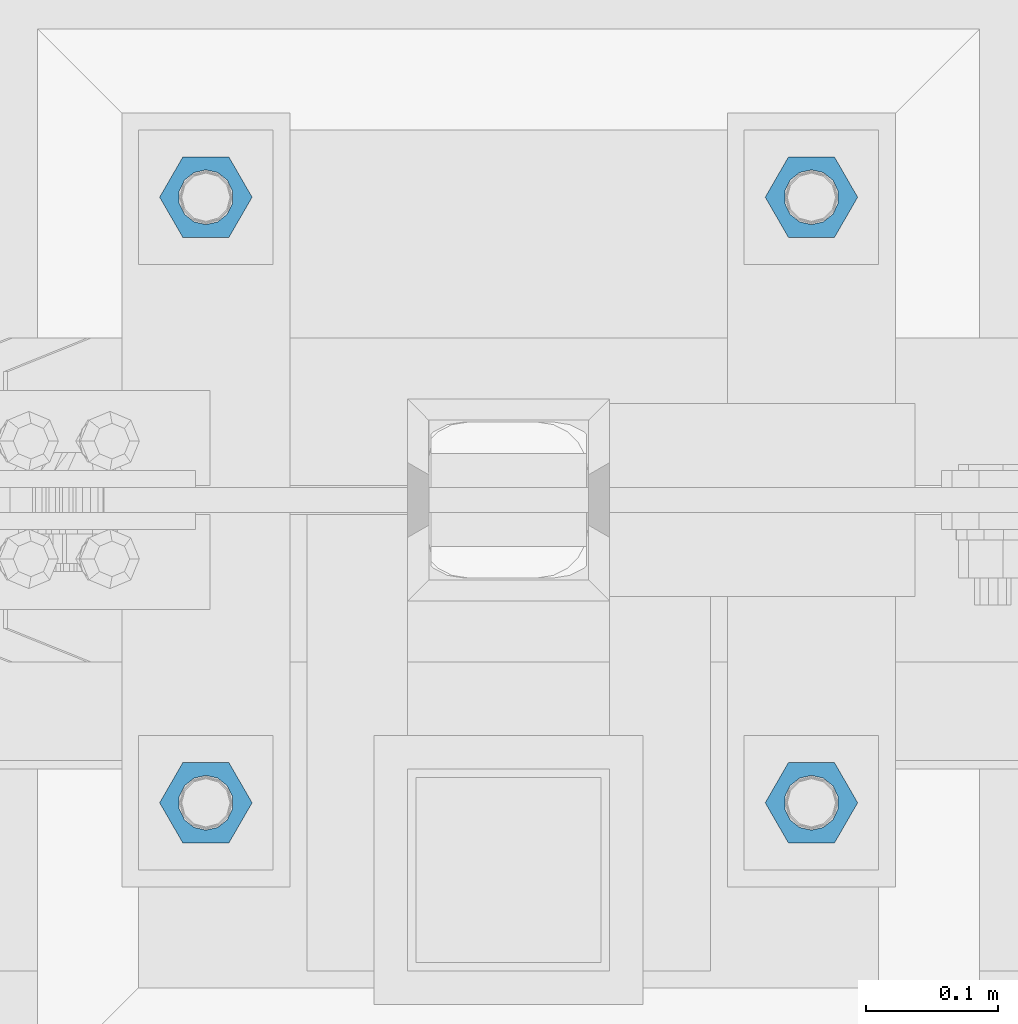
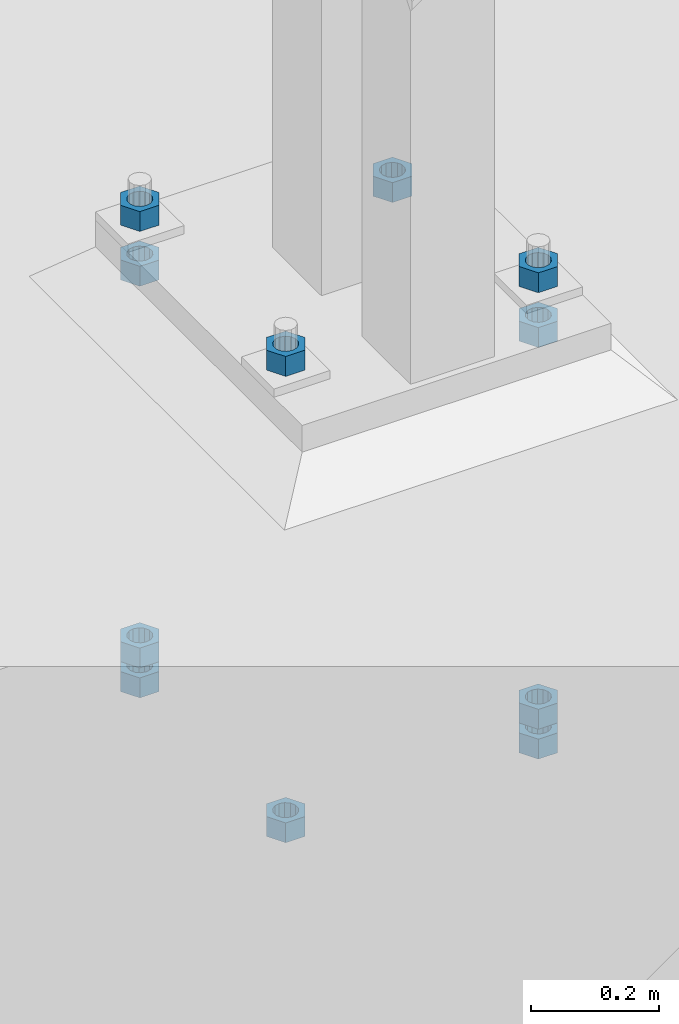
# One storey, part 960 of 1179: 11 beams, 1 element without a shape of its own.
"""IFC2X3 building model written with IfcOpenShell, lengths in millimetres."""

import ifcopenshell
import ifcopenshell.guid

model = None  # the IFC model being written
_history = None  # IfcOwnerHistory: only IFC2X3 demands one
_inside = {}  # id of a spatial element -> (the spatial element, [elements in it])
_under = {}  # id of a project, library or spatial element -> (it, [spatial elements below it])
_declared = {}  # id of a project -> (the project, [libraries it declares])
_typed = {}  # id of a type object -> (the type object, [elements of that type])
_made_of = {}  # id of a material, layer set ... -> (it, [elements and type objects made of it])


def new_model(schema):
    """Start an empty IFC model of exactly this schema.

    Asked for "IFC4X3", IfcOpenShell would pick the latest addendum, in which some entities
    have other attributes; the version numbers below select the first issue.
    IFC2X3 requires an IfcOwnerHistory on every rooted entity: one is made here for all.
    """
    global model, _history
    if schema == "IFC4X3":
        model = ifcopenshell.file(schema_version=(4, 3, 0, 0))
    else:
        model = ifcopenshell.file(schema=schema)
    _inside.clear()
    _under.clear()
    _declared.clear()
    _typed.clear()
    _made_of.clear()
    _history = None
    if model.schema == "IFC2X3":
        org = make("IfcOrganization", Name="unknown")
        user = make(
            "IfcPersonAndOrganization",
            ThePerson=make("IfcPerson", FamilyName="unknown"),
            TheOrganization=org,
        )
        app = make(
            "IfcApplication",
            ApplicationDeveloper=org,
            Version="unknown",
            ApplicationFullName="unknown",
            ApplicationIdentifier="unknown",
        )
        _history = make(
            "IfcOwnerHistory",
            OwningUser=user,
            OwningApplication=app,
            ChangeAction="ADDED",
            CreationDate=0,
        )
    return model


def make(cls, **values):
    """One entity of the class cls with the attributes given. An attribute that is None is left unset."""
    return model.create_entity(
        cls, **{name: value for name, value in values.items() if value is not None}
    )


def rooted(cls, **values):
    """An entity with a GlobalId (a new one), such as an element, a storey or a relation."""
    return make(cls, GlobalId=ifcopenshell.guid.new(), OwnerHistory=_history, **values)


def si_unit(unit_type, name, prefix=None):
    """IfcSIUnit, for example si_unit("LENGTHUNIT", "METRE", prefix="MILLI")."""
    return make("IfcSIUnit", UnitType=unit_type, Prefix=prefix, Name=name)


def assignment(units):
    """IfcUnitAssignment: the units of a project."""
    return None if units is None else make("IfcUnitAssignment", Units=units)


def point(xyz):
    """IfcCartesianPoint."""
    return None if xyz is None else make("IfcCartesianPoint", Coordinates=xyz)


def direction(xyz):
    """IfcDirection."""
    return None if xyz is None else make("IfcDirection", DirectionRatios=xyz)


def frame(location, z_axis=None, x_axis=None):
    """IfcAxis2Placement3D, a coordinate frame: its origin and axes. An axis left out is left unset."""
    return make(
        "IfcAxis2Placement3D",
        Location=point(location),
        Axis=direction(z_axis),
        RefDirection=direction(x_axis),
    )


def origin_with_axes():
    """The frame at (0, 0, 0) with the z axis (0, 0, 1) and the x axis (1, 0, 0) written out."""
    return frame((0.0, 0.0, 0.0), z_axis=(0.0, 0.0, 1.0), x_axis=(1.0, 0.0, 0.0))


def place(relative_to, where):
    """IfcLocalPlacement: puts the frame where relative to a parent placement (None: the world)."""
    return make(
        "IfcLocalPlacement", PlacementRelTo=relative_to, RelativePlacement=where
    )


def context(
    kind, dimensions, precision=None, world=None, true_north=None, identifier=None
):
    """IfcGeometricRepresentationContext, for example the 3D "Model" context."""
    return make(
        "IfcGeometricRepresentationContext",
        ContextIdentifier=identifier,
        ContextType=kind,
        CoordinateSpaceDimension=dimensions,
        Precision=precision,
        WorldCoordinateSystem=world,
        TrueNorth=true_north,
    )


def subcontext(parent, identifier, kind, view, scale=None):
    """IfcGeometricRepresentationSubContext, for example "Body" below "Model"."""
    return make(
        "IfcGeometricRepresentationSubContext",
        ContextIdentifier=identifier,
        ContextType=kind,
        ParentContext=parent,
        TargetScale=scale,
        TargetView=view,
    )


def project(units=None, contexts=None):
    """IfcProject with its units and contexts."""
    return rooted(
        "IfcProject",
        Name="project",
        RepresentationContexts=contexts,
        UnitsInContext=assignment(units),
    )


def spatial(cls, under=None, at=None, **own):
    """A site, building, storey or space (cls), placed at a placement, below another one or the project."""
    s = rooted(cls, ObjectPlacement=at, **own)
    if under is not None:
        _under.setdefault(under.id(), (under, []))[1].append(s)
    return s


def faces_of(points, faces, orient=None, outer=None):
    """IfcFace entities. A face is a list of loops; a loop is a list of indices into points, from 0.

    orient and outer hold one flag for each loop. By default every Orientation is true, the
    first loop of a face is its IfcFaceOuterBound and the others are IfcFaceBound.
    """
    made = []
    for i, loops in enumerate(faces):
        bounds = []
        for j, loop in enumerate(loops):
            is_outer = j == 0 if outer is None else outer[i][j]
            bounds.append(
                make(
                    "IfcFaceOuterBound" if is_outer else "IfcFaceBound",
                    Bound=make("IfcPolyLoop", Polygon=[points[k] for k in loop]),
                    Orientation=True if orient is None else orient[i][j],
                )
            )
        made.append(make("IfcFace", Bounds=bounds))
    return made


def faceted_brep(points, faces, orient=None, outer=None, voids=None):
    """IfcFacetedBrep: a solid bounded by flat faces; with voids (closed shells), ...WithVoids."""
    shared = [point(p) for p in points]
    hull = make("IfcClosedShell", CfsFaces=faces_of(shared, faces, orient, outer))
    if voids is None:
        return make("IfcFacetedBrep", Outer=hull)
    return make(
        "IfcFacetedBrepWithVoids",
        Outer=hull,
        Voids=[
            make(cls, CfsFaces=faces_of(shared, fs, o, b)) for cls, fs, o, b in voids
        ],
    )


def shape(context_of_items, identifier, shape_type, items):
    """IfcShapeRepresentation: the items that make up one representation, for example the "Body"."""
    return make(
        "IfcShapeRepresentation",
        ContextOfItems=context_of_items,
        RepresentationIdentifier=identifier,
        RepresentationType=shape_type,
        Items=items,
    )


def material(Name=None, Category=None):
    """IfcMaterial."""
    return make("IfcMaterial", Name=Name, Category=Category)


def made_of(thing, what):
    """Note that an element or type object is made of a material, layer set ...; save() writes the relation."""
    if what is not None:
        _made_of.setdefault(what.id(), (what, []))[1].append(thing)
    return thing


def type_object(cls, material=None, **own):
    """A type object (cls), such as IfcWallType, which elements share."""
    return made_of(rooted(cls, **own), material)


def element(
    cls,
    number,
    at=None,
    inside=None,
    cuts=None,
    type_object=None,
    material=None,
    context=None,
    identifier="Body",
    shape_type=None,
    held_by="IfcProductDefinitionShape",
    body=None,
    shapes=None,
    **own,
):
    """One element of the class cls, such as IfcWall. Its Tag is "e" and its number.

    at: its placement. inside: the storey or other place that contains it. cuts: it is an
    opening in that element (IfcRelVoidsElement). A single representation is given by context,
    identifier, shape_type and body (its items); several are given by shapes. held_by: the class
    of the entity that holds the representations. save() writes the other relations.
    """
    e = rooted(cls, Tag="e%d" % number, ObjectPlacement=at, **own)
    if body is not None:
        shapes = [shape(context, identifier, shape_type, body)]
    if shapes is not None:
        e.Representation = make(held_by, Representations=shapes)
    if inside is not None:
        _inside.setdefault(inside.id(), (inside, []))[1].append(e)
    if cuts is not None:
        rooted(
            "IfcRelVoidsElement", RelatingBuildingElement=cuts, RelatedOpeningElement=e
        )
    if type_object is not None:
        _typed.setdefault(type_object.id(), (type_object, []))[1].append(e)
    return made_of(e, material)


def aggregate(whole, parts):
    """IfcRelAggregates: a whole, such as a stair, and the parts it consists of."""
    return rooted("IfcRelAggregates", RelatingObject=whole, RelatedObjects=parts)


def save(model, path):
    """Write the relations noted so far, then the file.

    IfcRelAggregates (storeys below a building ...), IfcRelContainedInSpatialStructure (elements
    in a storey), IfcRelDefinesByType, IfcRelAssociatesMaterial and IfcRelDeclares: one each for
    every whole, place, type object, material and project.
    """
    for whole, parts in _under.values():
        aggregate(whole, parts)
    for where, things in _inside.values():
        rooted(
            "IfcRelContainedInSpatialStructure",
            RelatedElements=things,
            RelatingStructure=where,
        )
    for kind, things in _typed.values():
        rooted("IfcRelDefinesByType", RelatedObjects=things, RelatingType=kind)
    for what, things in _made_of.values():
        rooted("IfcRelAssociatesMaterial", RelatedObjects=things, RelatingMaterial=what)
    for by, libraries in _declared.values():
        rooted("IfcRelDeclares", RelatingContext=by, RelatedDefinitions=libraries)
    model.write(path)


model = new_model("IFC2X3")

# Units and contexts
model_context = context("Model", 3, precision=1e-05, world=origin_with_axes())
body_context = subcontext(model_context, "Body", "Model", "MODEL_VIEW")
ifc_project = project(units=[si_unit("LENGTHUNIT", "METRE", prefix="MILLI"), si_unit("AREAUNIT", "SQUARE_METRE"), si_unit("VOLUMEUNIT", "CUBIC_METRE"), si_unit("MASSUNIT", "GRAM", prefix="KILO"), si_unit("TIMEUNIT", "SECOND"), si_unit("PLANEANGLEUNIT", "RADIAN"), si_unit("SOLIDANGLEUNIT", "STERADIAN"), si_unit("THERMODYNAMICTEMPERATUREUNIT", "DEGREE_CELSIUS"), si_unit("LUMINOUSINTENSITYUNIT", "LUMEN")], contexts=[model_context])

# Site, building, storey
site_placement = place(None, origin_with_axes())
site = spatial("IfcSite", under=ifc_project, at=site_placement, CompositionType="ELEMENT")
building_placement = place(site_placement, origin_with_axes())
building = spatial("IfcBuilding", under=site, at=building_placement, Name="Undefined", CompositionType="ELEMENT")
storey_placement = place(building_placement, origin_with_axes())
storey = spatial("IfcBuildingStorey", under=building, at=storey_placement, Name="Undefined", CompositionType="ELEMENT", Elevation=0.0)

# Assembly, beams
assembly_placement = place(storey_placement, origin_with_axes())
assembly = element("IfcElementAssembly", 1, at=assembly_placement, inside=storey, Name="TEMPLATE", AssemblyPlace="NOTDEFINED", PredefinedType="RIGID_FRAME")
ifc_material = material(Name="STEEL/A36")
beam_type = type_object("IfcBeamType", Name="1-1/2_HEAVY_HEX_NUT", PredefinedType="NOTDEFINED")
beam_1_placement = place(assembly_placement, frame((27990.799987793, 4419.59999389648, -279.399999999999), z_axis=(0.0, 1.0, 0.0), x_axis=(0.0, 0.0, -1.0)))
beam_1 = element("IfcBeam", 2, at=beam_1_placement, type_object=beam_type, material=ifc_material, Name="NUT", ObjectType="1-1/2_HEAVY_HEX_NUT", context=body_context, shape_type="Brep", body=[
    faceted_brep([(0.0, -34.9199981689453, 0.0), (0.0, -17.4599990844727, -30.25), (38.0999999999985, -17.4599990844727, -30.25), (38.0999999999985, -34.9199981689453, 0.0), (0.0, 17.4599990844727, -30.25), (38.0999999999985, 17.4599990844727, -30.25), (0.0, 34.9199981689453, 0.0), (38.0999999999985, 34.9199981689453, 0.0), (0.0, 17.4599990844727, 30.25), (38.0999999999985, 17.4599990844727, 30.25), (0.0, -17.4599990844727, 30.25), (38.0999999999985, -17.4599990844727, 30.25), (0.0, 0.0, 20.6399993896484), (0.0, 8.95536011056538, 18.5959968835978), (38.0999999999985, 8.95536011056538, 18.5959968835978), (38.0999999999985, 0.0, 20.6399993896484), (0.0, 16.1370013209489, 12.8688291298158), (38.0999999999985, 16.1370013209489, 12.8688291298158), (0.0, 20.1225115123852, 4.59283194104228), (38.0999999999985, 20.1225115123852, 4.59283194104228), (0.0, 20.1225115123852, -4.59283194104228), (38.0999999999985, 20.1225115123852, -4.59283194104228), (0.0, 16.1370013209489, -12.8688291298167), (38.0999999999985, 16.1370013209489, -12.8688291298167), (0.0, 8.95536011056538, -18.5959968835978), (38.0999999999985, 8.95536011056538, -18.5959968835978), (0.0, 0.0, -20.6399993896484), (38.0999999999985, 0.0, -20.6399993896484), (0.0, -8.95536011056538, -18.5959968835978), (38.0999999999985, -8.95536011056538, -18.5959968835978), (0.0, -16.1370013209489, -12.8688291298158), (38.0999999999985, -16.1370013209489, -12.8688291298158), (0.0, -20.1225115123852, -4.59283194104228), (38.0999999999985, -20.1225115123852, -4.59283194104228), (0.0, -20.1225115123852, 4.59283194104228), (38.0999999999985, -20.1225115123852, 4.59283194104228), (0.0, -16.1370013209489, 12.8688291298167), (38.0999999999985, -16.1370013209489, 12.8688291298167), (0.0, -8.95536011056538, 18.5959968835978), (38.0999999999985, -8.95536011056538, 18.5959968835978)], [[[0, 1, 2, 3]], [[1, 4, 5, 2]], [[4, 6, 7, 5]], [[6, 8, 9, 7]], [[8, 10, 11, 9]], [[10, 0, 3, 11]], [[12, 13, 14, 15]], [[13, 16, 17, 14]], [[16, 18, 19, 17]], [[18, 20, 21, 19]], [[20, 22, 23, 21]], [[22, 24, 25, 23]], [[24, 26, 27, 25]], [[26, 28, 29, 27]], [[28, 30, 31, 29]], [[30, 32, 33, 31]], [[32, 34, 35, 33]], [[34, 36, 37, 35]], [[36, 38, 39, 37]], [[38, 12, 15, 39]], [[5, 7, 9, 11, 3, 2], [17, 19, 21, 23, 25, 27, 29, 31, 33, 35, 37, 39, 15, 14]], [[10, 8, 6, 4, 1, 0], [38, 36, 34, 32, 30, 28, 26, 24, 22, 20, 18, 16, 13, 12]]]),
])
beam_2_placement = place(assembly_placement, frame((27533.599987793, 4876.79999389648, -279.399999999999), z_axis=(0.0, -1.0, 0.0), x_axis=(0.0, 0.0, -1.0)))
beam_2 = element("IfcBeam", 3, at=beam_2_placement, type_object=beam_type, material=ifc_material, Name="NUT", ObjectType="1-1/2_HEAVY_HEX_NUT", context=body_context, shape_type="Brep", body=[
    faceted_brep([(0.0, -34.9199981689453, 0.0), (0.0, -17.4599990844727, -30.25), (38.0999999999985, -17.4599990844727, -30.25), (38.0999999999985, -34.9199981689453, 0.0), (0.0, 17.4599990844727, -30.25), (38.0999999999985, 17.4599990844727, -30.25), (0.0, 34.9199981689453, 0.0), (38.0999999999985, 34.9199981689453, 0.0), (0.0, 17.4599990844727, 30.25), (38.0999999999985, 17.4599990844727, 30.25), (0.0, -17.4599990844727, 30.25), (38.0999999999985, -17.4599990844727, 30.25), (0.0, 0.0, 20.6399993896484), (0.0, 8.95536011056538, 18.5959968835978), (38.0999999999985, 8.95536011056538, 18.5959968835978), (38.0999999999985, 0.0, 20.6399993896484), (0.0, 16.1370013209489, 12.8688291298158), (38.0999999999985, 16.1370013209489, 12.8688291298158), (0.0, 20.1225115123852, 4.59283194104228), (38.0999999999985, 20.1225115123852, 4.59283194104228), (0.0, 20.1225115123852, -4.59283194104228), (38.0999999999985, 20.1225115123852, -4.59283194104228), (0.0, 16.1370013209489, -12.8688291298167), (38.0999999999985, 16.1370013209489, -12.8688291298167), (0.0, 8.95536011056538, -18.5959968835978), (38.0999999999985, 8.95536011056538, -18.5959968835978), (0.0, 0.0, -20.6399993896484), (38.0999999999985, 0.0, -20.6399993896484), (0.0, -8.95536011056538, -18.5959968835978), (38.0999999999985, -8.95536011056538, -18.5959968835978), (0.0, -16.1370013209489, -12.8688291298158), (38.0999999999985, -16.1370013209489, -12.8688291298158), (0.0, -20.1225115123852, -4.59283194104228), (38.0999999999985, -20.1225115123852, -4.59283194104228), (0.0, -20.1225115123852, 4.59283194104228), (38.0999999999985, -20.1225115123852, 4.59283194104228), (0.0, -16.1370013209489, 12.8688291298167), (38.0999999999985, -16.1370013209489, 12.8688291298167), (0.0, -8.95536011056538, 18.5959968835978), (38.0999999999985, -8.95536011056538, 18.5959968835978)], [[[0, 1, 2, 3]], [[1, 4, 5, 2]], [[4, 6, 7, 5]], [[6, 8, 9, 7]], [[8, 10, 11, 9]], [[10, 0, 3, 11]], [[12, 13, 14, 15]], [[13, 16, 17, 14]], [[16, 18, 19, 17]], [[18, 20, 21, 19]], [[20, 22, 23, 21]], [[22, 24, 25, 23]], [[24, 26, 27, 25]], [[26, 28, 29, 27]], [[28, 30, 31, 29]], [[30, 32, 33, 31]], [[32, 34, 35, 33]], [[34, 36, 37, 35]], [[36, 38, 39, 37]], [[38, 12, 15, 39]], [[5, 7, 9, 11, 3, 2], [17, 19, 21, 23, 25, 27, 29, 31, 33, 35, 37, 39, 15, 14]], [[10, 8, 6, 4, 1, 0], [38, 36, 34, 32, 30, 28, 26, 24, 22, 20, 18, 16, 13, 12]]]),
])
beam_3_placement = place(assembly_placement, frame((27990.799987793, 4876.79999389648, -279.399999999999), z_axis=(0.0, 1.0, 0.0), x_axis=(0.0, 0.0, -1.0)))
beam_3 = element("IfcBeam", 4, at=beam_3_placement, type_object=beam_type, material=ifc_material, Name="NUT", ObjectType="1-1/2_HEAVY_HEX_NUT", context=body_context, shape_type="Brep", body=[
    faceted_brep([(0.0, -34.9199981689453, 0.0), (0.0, -17.4599990844727, -30.25), (38.0999999999985, -17.4599990844727, -30.25), (38.0999999999985, -34.9199981689453, 0.0), (0.0, 17.4599990844727, -30.25), (38.0999999999985, 17.4599990844727, -30.25), (0.0, 34.9199981689453, 0.0), (38.0999999999985, 34.9199981689453, 0.0), (0.0, 17.4599990844727, 30.25), (38.0999999999985, 17.4599990844727, 30.25), (0.0, -17.4599990844727, 30.25), (38.0999999999985, -17.4599990844727, 30.25), (0.0, 0.0, 20.6399993896484), (0.0, 8.95536011056538, 18.5959968835978), (38.0999999999985, 8.95536011056538, 18.5959968835978), (38.0999999999985, 0.0, 20.6399993896484), (0.0, 16.1370013209489, 12.8688291298158), (38.0999999999985, 16.1370013209489, 12.8688291298158), (0.0, 20.1225115123852, 4.59283194104228), (38.0999999999985, 20.1225115123852, 4.59283194104228), (0.0, 20.1225115123852, -4.59283194104228), (38.0999999999985, 20.1225115123852, -4.59283194104228), (0.0, 16.1370013209489, -12.8688291298167), (38.0999999999985, 16.1370013209489, -12.8688291298167), (0.0, 8.95536011056538, -18.5959968835978), (38.0999999999985, 8.95536011056538, -18.5959968835978), (0.0, 0.0, -20.6399993896484), (38.0999999999985, 0.0, -20.6399993896484), (0.0, -8.95536011056538, -18.5959968835978), (38.0999999999985, -8.95536011056538, -18.5959968835978), (0.0, -16.1370013209489, -12.8688291298158), (38.0999999999985, -16.1370013209489, -12.8688291298158), (0.0, -20.1225115123852, -4.59283194104228), (38.0999999999985, -20.1225115123852, -4.59283194104228), (0.0, -20.1225115123852, 4.59283194104228), (38.0999999999985, -20.1225115123852, 4.59283194104228), (0.0, -16.1370013209489, 12.8688291298167), (38.0999999999985, -16.1370013209489, 12.8688291298167), (0.0, -8.95536011056538, 18.5959968835978), (38.0999999999985, -8.95536011056538, 18.5959968835978)], [[[0, 1, 2, 3]], [[1, 4, 5, 2]], [[4, 6, 7, 5]], [[6, 8, 9, 7]], [[8, 10, 11, 9]], [[10, 0, 3, 11]], [[12, 13, 14, 15]], [[13, 16, 17, 14]], [[16, 18, 19, 17]], [[18, 20, 21, 19]], [[20, 22, 23, 21]], [[22, 24, 25, 23]], [[24, 26, 27, 25]], [[26, 28, 29, 27]], [[28, 30, 31, 29]], [[30, 32, 33, 31]], [[32, 34, 35, 33]], [[34, 36, 37, 35]], [[36, 38, 39, 37]], [[38, 12, 15, 39]], [[5, 7, 9, 11, 3, 2], [17, 19, 21, 23, 25, 27, 29, 31, 33, 35, 37, 39, 15, 14]], [[10, 8, 6, 4, 1, 0], [38, 36, 34, 32, 30, 28, 26, 24, 22, 20, 18, 16, 13, 12]]]),
])
beam_4_placement = place(assembly_placement, frame((27533.6, 4419.59999389648, -1066.79999923706), z_axis=(0.0, -1.0, 0.0), x_axis=(0.0, 0.0, -1.0)))
beam_4 = element("IfcBeam", 5, at=beam_4_placement, type_object=beam_type, material=ifc_material, Name="NUT", ObjectType="1-1/2_HEAVY_HEX_NUT", context=body_context, shape_type="Brep", body=[
    faceted_brep([(0.0, -34.9199981689453, 0.0), (0.0, -17.4599990844727, -30.25), (38.0999999999985, -17.4599990844727, -30.25), (38.0999999999985, -34.9199981689453, 0.0), (0.0, 17.4599990844727, -30.25), (38.0999999999985, 17.4599990844727, -30.25), (0.0, 34.9199981689453, 0.0), (38.0999999999985, 34.9199981689453, 0.0), (0.0, 17.4599990844727, 30.25), (38.0999999999985, 17.4599990844727, 30.25), (0.0, -17.4599990844727, 30.25), (38.0999999999985, -17.4599990844727, 30.25), (0.0, 0.0, 20.6399993896484), (0.0, 8.95536011056538, 18.5959968835978), (38.0999999999985, 8.95536011056538, 18.5959968835978), (38.0999999999985, 0.0, 20.6399993896484), (0.0, 16.1370013209489, 12.8688291298158), (38.0999999999985, 16.1370013209489, 12.8688291298158), (0.0, 20.1225115123852, 4.59283194104228), (38.0999999999985, 20.1225115123852, 4.59283194104228), (0.0, 20.1225115123852, -4.59283194104228), (38.0999999999985, 20.1225115123852, -4.59283194104228), (0.0, 16.1370013209489, -12.8688291298167), (38.0999999999985, 16.1370013209489, -12.8688291298167), (0.0, 8.95536011056538, -18.5959968835978), (38.0999999999985, 8.95536011056538, -18.5959968835978), (0.0, 0.0, -20.6399993896484), (38.0999999999985, 0.0, -20.6399993896484), (0.0, -8.95536011056538, -18.5959968835978), (38.0999999999985, -8.95536011056538, -18.5959968835978), (0.0, -16.1370013209489, -12.8688291298158), (38.0999999999985, -16.1370013209489, -12.8688291298158), (0.0, -20.1225115123852, -4.59283194104228), (38.0999999999985, -20.1225115123852, -4.59283194104228), (0.0, -20.1225115123852, 4.59283194104228), (38.0999999999985, -20.1225115123852, 4.59283194104228), (0.0, -16.1370013209489, 12.8688291298167), (38.0999999999985, -16.1370013209489, 12.8688291298167), (0.0, -8.95536011056538, 18.5959968835978), (38.0999999999985, -8.95536011056538, 18.5959968835978)], [[[0, 1, 2, 3]], [[1, 4, 5, 2]], [[4, 6, 7, 5]], [[6, 8, 9, 7]], [[8, 10, 11, 9]], [[10, 0, 3, 11]], [[12, 13, 14, 15]], [[13, 16, 17, 14]], [[16, 18, 19, 17]], [[18, 20, 21, 19]], [[20, 22, 23, 21]], [[22, 24, 25, 23]], [[24, 26, 27, 25]], [[26, 28, 29, 27]], [[28, 30, 31, 29]], [[30, 32, 33, 31]], [[32, 34, 35, 33]], [[34, 36, 37, 35]], [[36, 38, 39, 37]], [[38, 12, 15, 39]], [[5, 7, 9, 11, 3, 2], [17, 19, 21, 23, 25, 27, 29, 31, 33, 35, 37, 39, 15, 14]], [[10, 8, 6, 4, 1, 0], [38, 36, 34, 32, 30, 28, 26, 24, 22, 20, 18, 16, 13, 12]]]),
])
beam_5_placement = place(assembly_placement, frame((27533.6, 4876.79999389648, -1009.65), z_axis=(0.0, -1.0, 0.0), x_axis=(0.0, 0.0, -1.0)))
beam_5 = element("IfcBeam", 6, at=beam_5_placement, type_object=beam_type, material=ifc_material, Name="NUT", ObjectType="1-1/2_HEAVY_HEX_NUT", context=body_context, shape_type="Brep", body=[
    faceted_brep([(0.0, -34.9199981689453, 0.0), (0.0, -17.4599990844727, -30.25), (38.0999999999985, -17.4599990844727, -30.25), (38.0999999999985, -34.9199981689453, 0.0), (0.0, 17.4599990844727, -30.25), (38.0999999999985, 17.4599990844727, -30.25), (0.0, 34.9199981689453, 0.0), (38.0999999999985, 34.9199981689453, 0.0), (0.0, 17.4599990844727, 30.25), (38.0999999999985, 17.4599990844727, 30.25), (0.0, -17.4599990844727, 30.25), (38.0999999999985, -17.4599990844727, 30.25), (0.0, 0.0, 20.6399993896484), (0.0, 8.95536011056538, 18.5959968835978), (38.0999999999985, 8.95536011056538, 18.5959968835978), (38.0999999999985, 0.0, 20.6399993896484), (0.0, 16.1370013209489, 12.8688291298158), (38.0999999999985, 16.1370013209489, 12.8688291298158), (0.0, 20.1225115123852, 4.59283194104228), (38.0999999999985, 20.1225115123852, 4.59283194104228), (0.0, 20.1225115123852, -4.59283194104228), (38.0999999999985, 20.1225115123852, -4.59283194104228), (0.0, 16.1370013209489, -12.8688291298167), (38.0999999999985, 16.1370013209489, -12.8688291298167), (0.0, 8.95536011056538, -18.5959968835978), (38.0999999999985, 8.95536011056538, -18.5959968835978), (0.0, 0.0, -20.6399993896484), (38.0999999999985, 0.0, -20.6399993896484), (0.0, -8.95536011056538, -18.5959968835978), (38.0999999999985, -8.95536011056538, -18.5959968835978), (0.0, -16.1370013209489, -12.8688291298158), (38.0999999999985, -16.1370013209489, -12.8688291298158), (0.0, -20.1225115123852, -4.59283194104228), (38.0999999999985, -20.1225115123852, -4.59283194104228), (0.0, -20.1225115123852, 4.59283194104228), (38.0999999999985, -20.1225115123852, 4.59283194104228), (0.0, -16.1370013209489, 12.8688291298167), (38.0999999999985, -16.1370013209489, 12.8688291298167), (0.0, -8.95536011056538, 18.5959968835978), (38.0999999999985, -8.95536011056538, 18.5959968835978)], [[[0, 1, 2, 3]], [[1, 4, 5, 2]], [[4, 6, 7, 5]], [[6, 8, 9, 7]], [[8, 10, 11, 9]], [[10, 0, 3, 11]], [[12, 13, 14, 15]], [[13, 16, 17, 14]], [[16, 18, 19, 17]], [[18, 20, 21, 19]], [[20, 22, 23, 21]], [[22, 24, 25, 23]], [[24, 26, 27, 25]], [[26, 28, 29, 27]], [[28, 30, 31, 29]], [[30, 32, 33, 31]], [[32, 34, 35, 33]], [[34, 36, 37, 35]], [[36, 38, 39, 37]], [[38, 12, 15, 39]], [[5, 7, 9, 11, 3, 2], [17, 19, 21, 23, 25, 27, 29, 31, 33, 35, 37, 39, 15, 14]], [[10, 8, 6, 4, 1, 0], [38, 36, 34, 32, 30, 28, 26, 24, 22, 20, 18, 16, 13, 12]]]),
])
beam_6_placement = place(assembly_placement, frame((27533.6, 4876.80000610351, -1066.8), z_axis=(0.0, -1.0, 0.0), x_axis=(0.0, 0.0, -1.0)))
beam_6 = element("IfcBeam", 7, at=beam_6_placement, type_object=beam_type, material=ifc_material, Name="NUT", ObjectType="1-1/2_HEAVY_HEX_NUT", context=body_context, shape_type="Brep", body=[
    faceted_brep([(0.0, -34.9199981689453, 0.0), (0.0, -17.4599990844727, -30.25), (38.0999999999985, -17.4599990844727, -30.25), (38.0999999999985, -34.9199981689453, 0.0), (0.0, 17.4599990844727, -30.25), (38.0999999999985, 17.4599990844727, -30.25), (0.0, 34.9199981689453, 0.0), (38.0999999999985, 34.9199981689453, 0.0), (0.0, 17.4599990844727, 30.25), (38.0999999999985, 17.4599990844727, 30.25), (0.0, -17.4599990844727, 30.25), (38.0999999999985, -17.4599990844727, 30.25), (0.0, 0.0, 20.6399993896484), (0.0, 8.95536011056538, 18.5959968835978), (38.0999999999985, 8.95536011056538, 18.5959968835978), (38.0999999999985, 0.0, 20.6399993896484), (0.0, 16.1370013209489, 12.8688291298158), (38.0999999999985, 16.1370013209489, 12.8688291298158), (0.0, 20.1225115123852, 4.59283194104228), (38.0999999999985, 20.1225115123852, 4.59283194104228), (0.0, 20.1225115123852, -4.59283194104228), (38.0999999999985, 20.1225115123852, -4.59283194104228), (0.0, 16.1370013209489, -12.8688291298167), (38.0999999999985, 16.1370013209489, -12.8688291298167), (0.0, 8.95536011056538, -18.5959968835978), (38.0999999999985, 8.95536011056538, -18.5959968835978), (0.0, 0.0, -20.6399993896484), (38.0999999999985, 0.0, -20.6399993896484), (0.0, -8.95536011056538, -18.5959968835978), (38.0999999999985, -8.95536011056538, -18.5959968835978), (0.0, -16.1370013209489, -12.8688291298158), (38.0999999999985, -16.1370013209489, -12.8688291298158), (0.0, -20.1225115123852, -4.59283194104228), (38.0999999999985, -20.1225115123852, -4.59283194104228), (0.0, -20.1225115123852, 4.59283194104228), (38.0999999999985, -20.1225115123852, 4.59283194104228), (0.0, -16.1370013209489, 12.8688291298167), (38.0999999999985, -16.1370013209489, 12.8688291298167), (0.0, -8.95536011056538, 18.5959968835978), (38.0999999999985, -8.95536011056538, 18.5959968835978)], [[[0, 1, 2, 3]], [[1, 4, 5, 2]], [[4, 6, 7, 5]], [[6, 8, 9, 7]], [[8, 10, 11, 9]], [[10, 0, 3, 11]], [[12, 13, 14, 15]], [[13, 16, 17, 14]], [[16, 18, 19, 17]], [[18, 20, 21, 19]], [[20, 22, 23, 21]], [[22, 24, 25, 23]], [[24, 26, 27, 25]], [[26, 28, 29, 27]], [[28, 30, 31, 29]], [[30, 32, 33, 31]], [[32, 34, 35, 33]], [[34, 36, 37, 35]], [[36, 38, 39, 37]], [[38, 12, 15, 39]], [[5, 7, 9, 11, 3, 2], [17, 19, 21, 23, 25, 27, 29, 31, 33, 35, 37, 39, 15, 14]], [[10, 8, 6, 4, 1, 0], [38, 36, 34, 32, 30, 28, 26, 24, 22, 20, 18, 16, 13, 12]]]),
])
beam_7_placement = place(assembly_placement, frame((27990.8, 4419.59999389648, -1009.65), z_axis=(0.0, -1.0, 0.0), x_axis=(0.0, 0.0, -1.0)))
beam_7 = element("IfcBeam", 8, at=beam_7_placement, type_object=beam_type, material=ifc_material, Name="NUT", ObjectType="1-1/2_HEAVY_HEX_NUT", context=body_context, shape_type="Brep", body=[
    faceted_brep([(0.0, -34.9199981689453, 0.0), (0.0, -17.4599990844727, -30.25), (38.0999999999985, -17.4599990844727, -30.25), (38.0999999999985, -34.9199981689453, 0.0), (0.0, 17.4599990844727, -30.25), (38.0999999999985, 17.4599990844727, -30.25), (0.0, 34.9199981689453, 0.0), (38.0999999999985, 34.9199981689453, 0.0), (0.0, 17.4599990844727, 30.25), (38.0999999999985, 17.4599990844727, 30.25), (0.0, -17.4599990844727, 30.25), (38.0999999999985, -17.4599990844727, 30.25), (0.0, 0.0, 20.6399993896484), (0.0, 8.95536011056538, 18.5959968835978), (38.0999999999985, 8.95536011056538, 18.5959968835978), (38.0999999999985, 0.0, 20.6399993896484), (0.0, 16.1370013209489, 12.8688291298158), (38.0999999999985, 16.1370013209489, 12.8688291298158), (0.0, 20.1225115123852, 4.59283194104228), (38.0999999999985, 20.1225115123852, 4.59283194104228), (0.0, 20.1225115123852, -4.59283194104228), (38.0999999999985, 20.1225115123852, -4.59283194104228), (0.0, 16.1370013209489, -12.8688291298167), (38.0999999999985, 16.1370013209489, -12.8688291298167), (0.0, 8.95536011056538, -18.5959968835978), (38.0999999999985, 8.95536011056538, -18.5959968835978), (0.0, 0.0, -20.6399993896484), (38.0999999999985, 0.0, -20.6399993896484), (0.0, -8.95536011056538, -18.5959968835978), (38.0999999999985, -8.95536011056538, -18.5959968835978), (0.0, -16.1370013209489, -12.8688291298158), (38.0999999999985, -16.1370013209489, -12.8688291298158), (0.0, -20.1225115123852, -4.59283194104228), (38.0999999999985, -20.1225115123852, -4.59283194104228), (0.0, -20.1225115123852, 4.59283194104228), (38.0999999999985, -20.1225115123852, 4.59283194104228), (0.0, -16.1370013209489, 12.8688291298167), (38.0999999999985, -16.1370013209489, 12.8688291298167), (0.0, -8.95536011056538, 18.5959968835978), (38.0999999999985, -8.95536011056538, 18.5959968835978)], [[[0, 1, 2, 3]], [[1, 4, 5, 2]], [[4, 6, 7, 5]], [[6, 8, 9, 7]], [[8, 10, 11, 9]], [[10, 0, 3, 11]], [[12, 13, 14, 15]], [[13, 16, 17, 14]], [[16, 18, 19, 17]], [[18, 20, 21, 19]], [[20, 22, 23, 21]], [[22, 24, 25, 23]], [[24, 26, 27, 25]], [[26, 28, 29, 27]], [[28, 30, 31, 29]], [[30, 32, 33, 31]], [[32, 34, 35, 33]], [[34, 36, 37, 35]], [[36, 38, 39, 37]], [[38, 12, 15, 39]], [[5, 7, 9, 11, 3, 2], [17, 19, 21, 23, 25, 27, 29, 31, 33, 35, 37, 39, 15, 14]], [[10, 8, 6, 4, 1, 0], [38, 36, 34, 32, 30, 28, 26, 24, 22, 20, 18, 16, 13, 12]]]),
])
beam_8_placement = place(assembly_placement, frame((27990.8, 4419.59999389648, -1066.8), z_axis=(0.0, -1.0, 0.0), x_axis=(0.0, 0.0, -1.0)))
beam_8 = element("IfcBeam", 9, at=beam_8_placement, type_object=beam_type, material=ifc_material, Name="NUT", ObjectType="1-1/2_HEAVY_HEX_NUT", context=body_context, shape_type="Brep", body=[
    faceted_brep([(0.0, -34.9199981689453, 0.0), (0.0, -17.4599990844727, -30.25), (38.0999999999985, -17.4599990844727, -30.25), (38.0999999999985, -34.9199981689453, 0.0), (0.0, 17.4599990844727, -30.25), (38.0999999999985, 17.4599990844727, -30.25), (0.0, 34.9199981689453, 0.0), (38.0999999999985, 34.9199981689453, 0.0), (0.0, 17.4599990844727, 30.25), (38.0999999999985, 17.4599990844727, 30.25), (0.0, -17.4599990844727, 30.25), (38.0999999999985, -17.4599990844727, 30.25), (0.0, 0.0, 20.6399993896484), (0.0, 8.95536011056538, 18.5959968835978), (38.0999999999985, 8.95536011056538, 18.5959968835978), (38.0999999999985, 0.0, 20.6399993896484), (0.0, 16.1370013209489, 12.8688291298158), (38.0999999999985, 16.1370013209489, 12.8688291298158), (0.0, 20.1225115123852, 4.59283194104228), (38.0999999999985, 20.1225115123852, 4.59283194104228), (0.0, 20.1225115123852, -4.59283194104228), (38.0999999999985, 20.1225115123852, -4.59283194104228), (0.0, 16.1370013209489, -12.8688291298167), (38.0999999999985, 16.1370013209489, -12.8688291298167), (0.0, 8.95536011056538, -18.5959968835978), (38.0999999999985, 8.95536011056538, -18.5959968835978), (0.0, 0.0, -20.6399993896484), (38.0999999999985, 0.0, -20.6399993896484), (0.0, -8.95536011056538, -18.5959968835978), (38.0999999999985, -8.95536011056538, -18.5959968835978), (0.0, -16.1370013209489, -12.8688291298158), (38.0999999999985, -16.1370013209489, -12.8688291298158), (0.0, -20.1225115123852, -4.59283194104228), (38.0999999999985, -20.1225115123852, -4.59283194104228), (0.0, -20.1225115123852, 4.59283194104228), (38.0999999999985, -20.1225115123852, 4.59283194104228), (0.0, -16.1370013209489, 12.8688291298167), (38.0999999999985, -16.1370013209489, 12.8688291298167), (0.0, -8.95536011056538, 18.5959968835978), (38.0999999999985, -8.95536011056538, 18.5959968835978)], [[[0, 1, 2, 3]], [[1, 4, 5, 2]], [[4, 6, 7, 5]], [[6, 8, 9, 7]], [[8, 10, 11, 9]], [[10, 0, 3, 11]], [[12, 13, 14, 15]], [[13, 16, 17, 14]], [[16, 18, 19, 17]], [[18, 20, 21, 19]], [[20, 22, 23, 21]], [[22, 24, 25, 23]], [[24, 26, 27, 25]], [[26, 28, 29, 27]], [[28, 30, 31, 29]], [[30, 32, 33, 31]], [[32, 34, 35, 33]], [[34, 36, 37, 35]], [[36, 38, 39, 37]], [[38, 12, 15, 39]], [[5, 7, 9, 11, 3, 2], [17, 19, 21, 23, 25, 27, 29, 31, 33, 35, 37, 39, 15, 14]], [[10, 8, 6, 4, 1, 0], [38, 36, 34, 32, 30, 28, 26, 24, 22, 20, 18, 16, 13, 12]]]),
])
beam_9_placement = place(assembly_placement, frame((27533.6, 4419.59999389648, -174.625), z_axis=(0.0, -1.0, 0.0), x_axis=(0.0, 0.0, -1.0)))
beam_9 = element("IfcBeam", 10, at=beam_9_placement, type_object=beam_type, material=ifc_material, Name="NUT", ObjectType="1-1/2_HEAVY_HEX_NUT", context=body_context, shape_type="Brep", body=[
    faceted_brep([(0.0, -34.9199981689453, 0.0), (0.0, -17.4599990844727, -30.25), (38.0999999999985, -17.4599990844727, -30.25), (38.0999999999985, -34.9199981689453, 0.0), (0.0, 17.4599990844727, -30.25), (38.0999999999985, 17.4599990844727, -30.25), (0.0, 34.9199981689453, 0.0), (38.0999999999985, 34.9199981689453, 0.0), (0.0, 17.4599990844727, 30.25), (38.0999999999985, 17.4599990844727, 30.25), (0.0, -17.4599990844727, 30.25), (38.0999999999985, -17.4599990844727, 30.25), (0.0, 0.0, 20.6399993896484), (0.0, 8.95536011056538, 18.5959968835978), (38.0999999999985, 8.95536011056538, 18.5959968835978), (38.0999999999985, 0.0, 20.6399993896484), (0.0, 16.1370013209489, 12.8688291298158), (38.0999999999985, 16.1370013209489, 12.8688291298158), (0.0, 20.1225115123852, 4.59283194104228), (38.0999999999985, 20.1225115123852, 4.59283194104228), (0.0, 20.1225115123852, -4.59283194104228), (38.0999999999985, 20.1225115123852, -4.59283194104228), (0.0, 16.1370013209489, -12.8688291298167), (38.0999999999985, 16.1370013209489, -12.8688291298167), (0.0, 8.95536011056538, -18.5959968835978), (38.0999999999985, 8.95536011056538, -18.5959968835978), (0.0, 0.0, -20.6399993896484), (38.0999999999985, 0.0, -20.6399993896484), (0.0, -8.95536011056538, -18.5959968835978), (38.0999999999985, -8.95536011056538, -18.5959968835978), (0.0, -16.1370013209489, -12.8688291298158), (38.0999999999985, -16.1370013209489, -12.8688291298158), (0.0, -20.1225115123852, -4.59283194104228), (38.0999999999985, -20.1225115123852, -4.59283194104228), (0.0, -20.1225115123852, 4.59283194104228), (38.0999999999985, -20.1225115123852, 4.59283194104228), (0.0, -16.1370013209489, 12.8688291298167), (38.0999999999985, -16.1370013209489, 12.8688291298167), (0.0, -8.95536011056538, 18.5959968835978), (38.0999999999985, -8.95536011056538, 18.5959968835978)], [[[0, 1, 2, 3]], [[1, 4, 5, 2]], [[4, 6, 7, 5]], [[6, 8, 9, 7]], [[8, 10, 11, 9]], [[10, 0, 3, 11]], [[12, 13, 14, 15]], [[13, 16, 17, 14]], [[16, 18, 19, 17]], [[18, 20, 21, 19]], [[20, 22, 23, 21]], [[22, 24, 25, 23]], [[24, 26, 27, 25]], [[26, 28, 29, 27]], [[28, 30, 31, 29]], [[30, 32, 33, 31]], [[32, 34, 35, 33]], [[34, 36, 37, 35]], [[36, 38, 39, 37]], [[38, 12, 15, 39]], [[5, 7, 9, 11, 3, 2], [17, 19, 21, 23, 25, 27, 29, 31, 33, 35, 37, 39, 15, 14]], [[10, 8, 6, 4, 1, 0], [38, 36, 34, 32, 30, 28, 26, 24, 22, 20, 18, 16, 13, 12]]]),
])
beam_10_placement = place(assembly_placement, frame((27990.8, 4419.59999389648, -174.625), z_axis=(0.0, 1.0, 0.0), x_axis=(0.0, 0.0, -1.0)))
beam_10 = element("IfcBeam", 11, at=beam_10_placement, type_object=beam_type, material=ifc_material, Name="NUT", ObjectType="1-1/2_HEAVY_HEX_NUT", context=body_context, shape_type="Brep", body=[
    faceted_brep([(0.0, -34.9199981689453, 0.0), (0.0, -17.4599990844727, -30.25), (38.0999999999985, -17.4599990844727, -30.25), (38.0999999999985, -34.9199981689453, 0.0), (0.0, 17.4599990844727, -30.25), (38.0999999999985, 17.4599990844727, -30.25), (0.0, 34.9199981689453, 0.0), (38.0999999999985, 34.9199981689453, 0.0), (0.0, 17.4599990844727, 30.25), (38.0999999999985, 17.4599990844727, 30.25), (0.0, -17.4599990844727, 30.25), (38.0999999999985, -17.4599990844727, 30.25), (0.0, 0.0, 20.6399993896484), (0.0, 8.95536011056538, 18.5959968835978), (38.0999999999985, 8.95536011056538, 18.5959968835978), (38.0999999999985, 0.0, 20.6399993896484), (0.0, 16.1370013209489, 12.8688291298158), (38.0999999999985, 16.1370013209489, 12.8688291298158), (0.0, 20.1225115123852, 4.59283194104228), (38.0999999999985, 20.1225115123852, 4.59283194104228), (0.0, 20.1225115123852, -4.59283194104228), (38.0999999999985, 20.1225115123852, -4.59283194104228), (0.0, 16.1370013209489, -12.8688291298167), (38.0999999999985, 16.1370013209489, -12.8688291298167), (0.0, 8.95536011056538, -18.5959968835978), (38.0999999999985, 8.95536011056538, -18.5959968835978), (0.0, 0.0, -20.6399993896484), (38.0999999999985, 0.0, -20.6399993896484), (0.0, -8.95536011056538, -18.5959968835978), (38.0999999999985, -8.95536011056538, -18.5959968835978), (0.0, -16.1370013209489, -12.8688291298158), (38.0999999999985, -16.1370013209489, -12.8688291298158), (0.0, -20.1225115123852, -4.59283194104228), (38.0999999999985, -20.1225115123852, -4.59283194104228), (0.0, -20.1225115123852, 4.59283194104228), (38.0999999999985, -20.1225115123852, 4.59283194104228), (0.0, -16.1370013209489, 12.8688291298167), (38.0999999999985, -16.1370013209489, 12.8688291298167), (0.0, -8.95536011056538, 18.5959968835978), (38.0999999999985, -8.95536011056538, 18.5959968835978)], [[[0, 1, 2, 3]], [[1, 4, 5, 2]], [[4, 6, 7, 5]], [[6, 8, 9, 7]], [[8, 10, 11, 9]], [[10, 0, 3, 11]], [[12, 13, 14, 15]], [[13, 16, 17, 14]], [[16, 18, 19, 17]], [[18, 20, 21, 19]], [[20, 22, 23, 21]], [[22, 24, 25, 23]], [[24, 26, 27, 25]], [[26, 28, 29, 27]], [[28, 30, 31, 29]], [[30, 32, 33, 31]], [[32, 34, 35, 33]], [[34, 36, 37, 35]], [[36, 38, 39, 37]], [[38, 12, 15, 39]], [[5, 7, 9, 11, 3, 2], [17, 19, 21, 23, 25, 27, 29, 31, 33, 35, 37, 39, 15, 14]], [[10, 8, 6, 4, 1, 0], [38, 36, 34, 32, 30, 28, 26, 24, 22, 20, 18, 16, 13, 12]]]),
])
beam_11_placement = place(assembly_placement, frame((27533.6, 4876.79999389648, -174.625), z_axis=(0.0, -1.0, 0.0), x_axis=(0.0, 0.0, -1.0)))
beam_11 = element("IfcBeam", 12, at=beam_11_placement, type_object=beam_type, material=ifc_material, Name="NUT", ObjectType="1-1/2_HEAVY_HEX_NUT", context=body_context, shape_type="Brep", body=[
    faceted_brep([(0.0, -34.9199981689453, 0.0), (0.0, -17.4599990844727, -30.25), (38.0999999999985, -17.4599990844727, -30.25), (38.0999999999985, -34.9199981689453, 0.0), (0.0, 17.4599990844727, -30.25), (38.0999999999985, 17.4599990844727, -30.25), (0.0, 34.9199981689453, 0.0), (38.0999999999985, 34.9199981689453, 0.0), (0.0, 17.4599990844727, 30.25), (38.0999999999985, 17.4599990844727, 30.25), (0.0, -17.4599990844727, 30.25), (38.0999999999985, -17.4599990844727, 30.25), (0.0, 0.0, 20.6399993896484), (0.0, 8.95536011056538, 18.5959968835978), (38.0999999999985, 8.95536011056538, 18.5959968835978), (38.0999999999985, 0.0, 20.6399993896484), (0.0, 16.1370013209489, 12.8688291298158), (38.0999999999985, 16.1370013209489, 12.8688291298158), (0.0, 20.1225115123852, 4.59283194104228), (38.0999999999985, 20.1225115123852, 4.59283194104228), (0.0, 20.1225115123852, -4.59283194104228), (38.0999999999985, 20.1225115123852, -4.59283194104228), (0.0, 16.1370013209489, -12.8688291298167), (38.0999999999985, 16.1370013209489, -12.8688291298167), (0.0, 8.95536011056538, -18.5959968835978), (38.0999999999985, 8.95536011056538, -18.5959968835978), (0.0, 0.0, -20.6399993896484), (38.0999999999985, 0.0, -20.6399993896484), (0.0, -8.95536011056538, -18.5959968835978), (38.0999999999985, -8.95536011056538, -18.5959968835978), (0.0, -16.1370013209489, -12.8688291298158), (38.0999999999985, -16.1370013209489, -12.8688291298158), (0.0, -20.1225115123852, -4.59283194104228), (38.0999999999985, -20.1225115123852, -4.59283194104228), (0.0, -20.1225115123852, 4.59283194104228), (38.0999999999985, -20.1225115123852, 4.59283194104228), (0.0, -16.1370013209489, 12.8688291298167), (38.0999999999985, -16.1370013209489, 12.8688291298167), (0.0, -8.95536011056538, 18.5959968835978), (38.0999999999985, -8.95536011056538, 18.5959968835978)], [[[0, 1, 2, 3]], [[1, 4, 5, 2]], [[4, 6, 7, 5]], [[6, 8, 9, 7]], [[8, 10, 11, 9]], [[10, 0, 3, 11]], [[12, 13, 14, 15]], [[13, 16, 17, 14]], [[16, 18, 19, 17]], [[18, 20, 21, 19]], [[20, 22, 23, 21]], [[22, 24, 25, 23]], [[24, 26, 27, 25]], [[26, 28, 29, 27]], [[28, 30, 31, 29]], [[30, 32, 33, 31]], [[32, 34, 35, 33]], [[34, 36, 37, 35]], [[36, 38, 39, 37]], [[38, 12, 15, 39]], [[5, 7, 9, 11, 3, 2], [17, 19, 21, 23, 25, 27, 29, 31, 33, 35, 37, 39, 15, 14]], [[10, 8, 6, 4, 1, 0], [38, 36, 34, 32, 30, 28, 26, 24, 22, 20, 18, 16, 13, 12]]]),
])
aggregate(assembly, [beam_1, beam_2, beam_3, beam_4, beam_5, beam_6, beam_7, beam_8, beam_9, beam_10, beam_11])

save(model, "model.ifc")
